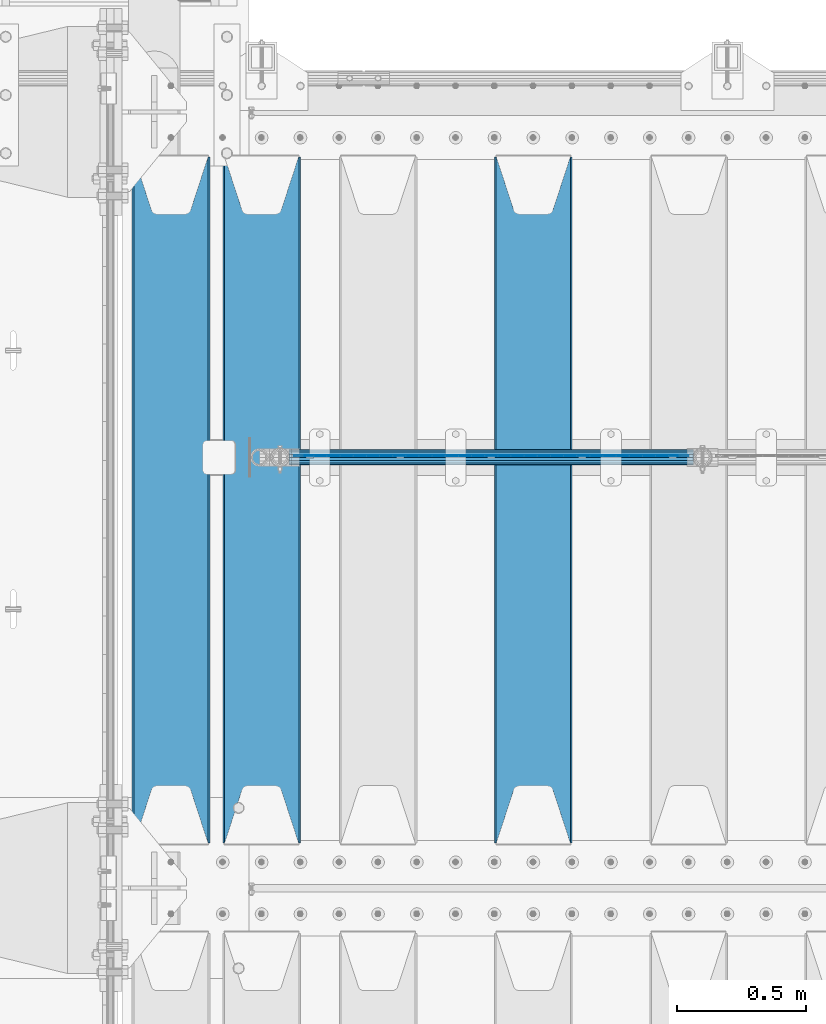
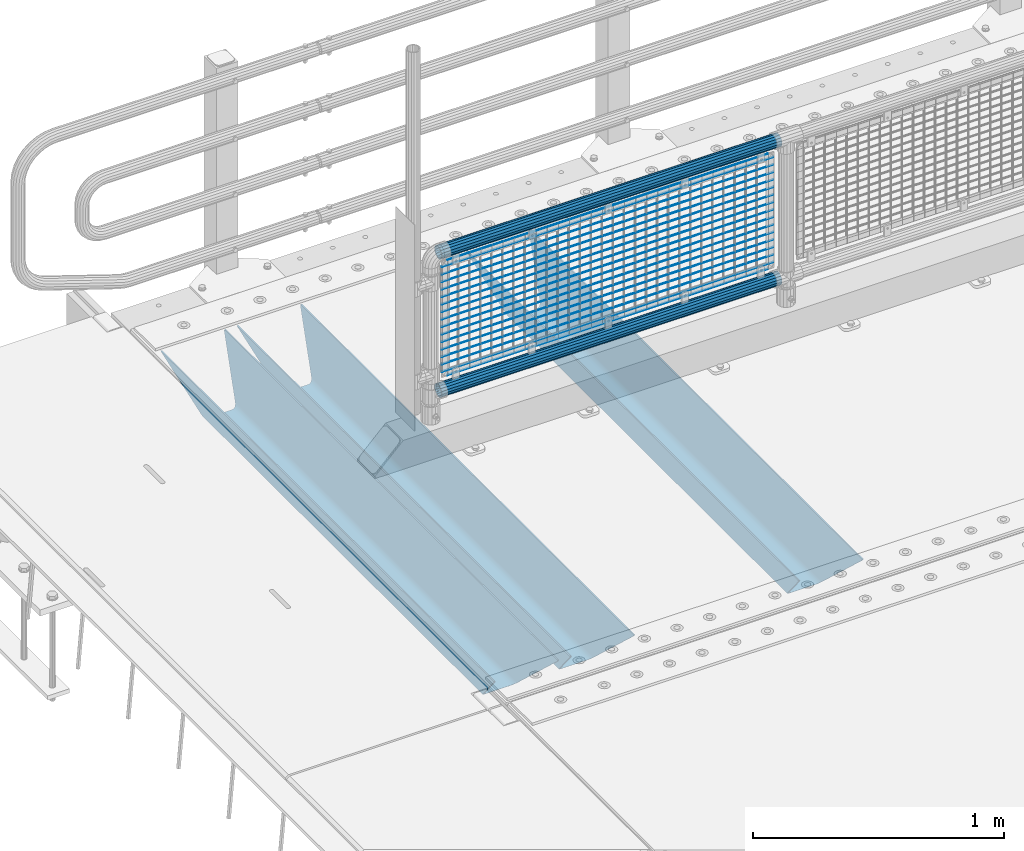
# One storey, part 113 of 242: 22 beams.
"""IFC2X3 building model written with IfcOpenShell, lengths in millimetres."""

from ifc_helpers import new_model, si_unit, frame, origin_with_axes, place, context, subcontext, project, spatial, faceted_brep, material, type_object, element, save


model = new_model("IFC2X3")

# Units and contexts
model_context = context("Model", 3, precision=1e-05, world=origin_with_axes())
body_context = subcontext(model_context, "Body", "Model", "MODEL_VIEW")
ifc_project = project(units=[si_unit("LENGTHUNIT", "METRE", prefix="MILLI"), si_unit("AREAUNIT", "SQUARE_METRE"), si_unit("VOLUMEUNIT", "CUBIC_METRE"), si_unit("MASSUNIT", "GRAM", prefix="KILO"), si_unit("TIMEUNIT", "SECOND"), si_unit("PLANEANGLEUNIT", "RADIAN"), si_unit("SOLIDANGLEUNIT", "STERADIAN"), si_unit("THERMODYNAMICTEMPERATUREUNIT", "DEGREE_CELSIUS"), si_unit("LUMINOUSINTENSITYUNIT", "LUMEN")], contexts=[model_context])

# Site, building, storey
site_placement = place(None, origin_with_axes())
site = spatial("IfcSite", under=ifc_project, at=site_placement, CompositionType="ELEMENT")
building_placement = place(site_placement, origin_with_axes())
building = spatial("IfcBuilding", under=site, at=building_placement, Name="Standard", CompositionType="ELEMENT")
storey_placement = place(building_placement, origin_with_axes())
storey = spatial("IfcBuildingStorey", under=building, at=storey_placement, Name="Undefined", CompositionType="ELEMENT", Elevation=0.0)

# Beams
ifc_material_1 = material(Name="Misc_Undefined")
beam_type_1 = type_object("IfcBeamType", Name="D3", PredefinedType="NOTDEFINED")
for number, where, z_axis, x_axis in (
    (1, (-41774.0, -19329.5, 851.596999999999), (0.0, 0.0, 1.0), (1.0, 0.0, 0.0)),
    (2, (-41774.0, -19329.5, 669.452), (0.0, 0.0, 1.0), (1.0, 0.0, 0.0)),
    (3, (-41774.0, -19329.5, 523.736), (0.0, 0.0, 1.0), (1.0, 0.0, 0.0)),
    (4, (-41774.0, -19329.5, 487.307), (0.0, 0.0, 1.0), (1.0, 0.0, 0.0)),
    (5, (-41774.0, -19329.5, 705.881), (0.0, 0.0, 1.0), (1.0, 0.0, 0.0)),
    (6, (-41774.0, -19329.5, 596.594), (0.0, 0.0, 1.0), (1.0, 0.0, 0.0)),
    (7, (-41774.0, -19329.5, 450.878), (0.0, 0.0, 1.0), (1.0, 0.0, 0.0)),
    (8, (-41774.0, -19329.5, 815.167999999999), (0.0, 0.0, 1.0), (1.0, 0.0, 0.0)),
    (9, (-41774.0, -19329.5, 888.025999999999), (0.0, 0.0, 1.0), (1.0, 0.0, 0.0)),
    (10, (-41774.0, -19329.5, 778.738999999999), (0.0, 0.0, 1.0), (1.0, 0.0, 0.0)),
    (11, (-41774.0, -19329.5, 742.309999999999), (0.0, 0.0, 1.0), (1.0, 0.0, 0.0)),
    (12, (-41774.0, -19329.5, 633.023), (0.0, 0.0, 1.0), (1.0, 0.0, 0.0)),
    (13, (-41774.0, -19329.5, 560.165), (0.0, 0.0, 1.0), (1.0, 0.0, 0.0)),
    (14, (-41774.0, -19329.5, 414.449), (0.0, 0.0, 1.0), (1.0, 0.0, 0.0)),
):
    element("IfcBeam", number, at=place(storey_placement, frame(where, z_axis=z_axis, x_axis=x_axis)), inside=storey, type_object=beam_type_1, material=ifc_material_1, ObjectType="D3", context=body_context, shape_type="Brep", body=[
        faceted_brep([(0.0, -1.50000000000364, 0.0), (-3.63797880709171e-12, -0.750000000003638, -1.29903810567669), (1523.0, -0.75, -1.29903810567669), (1523.0, -1.5, 0.0), (0.0, 0.749999999996362, -1.29903810567669), (1523.0, 0.75, -1.29903810567669), (-3.63797880709171e-12, 1.49999999999636, 0.0), (1523.0, 1.5, 0.0), (0.0, 0.749999999996362, 1.29903810567669), (1523.0, 0.75, 1.29903810567669), (-3.63797880709171e-12, -0.750000000003638, 1.29903810567669), (1523.0, -0.75, 1.29903810567669)], [[[0, 1, 2, 3]], [[1, 4, 5, 2]], [[4, 6, 7, 5]], [[6, 8, 9, 7]], [[8, 10, 11, 9]], [[10, 0, 3, 11]], [[5, 7, 9, 11, 3, 2]], [[10, 8, 6, 4, 1, 0]]]),
    ])
beam_1_placement = place(storey_placement, frame((-41749.0, -19329.5, 353.02), z_axis=(0.0, 0.0, 1.0), x_axis=(1.0, 0.0, 0.0)))
element("IfcBeam", 15, at=beam_1_placement, inside=storey, type_object=beam_type_1, material=ifc_material_1, ObjectType="D3", context=body_context, shape_type="Brep", body=[
    faceted_brep([(0.0, -1.50000000000364, 0.0), (-3.63797880709171e-12, -0.750000000003638, -1.29903810567669), (1473.0, -0.75, -1.29903810567669), (1473.0, -1.5, 0.0), (0.0, 0.749999999996362, -1.29903810567669), (1473.0, 0.75, -1.29903810567663), (-3.63797880709171e-12, 1.49999999999636, 0.0), (1473.0, 1.5, 0.0), (0.0, 0.749999999996362, 1.29903810567669), (1473.0, 0.75, 1.29903810567669), (-3.63797880709171e-12, -0.750000000003638, 1.29903810567669), (1473.0, -0.75, 1.29903810567669)], [[[0, 1, 2, 3]], [[1, 4, 5, 2]], [[4, 6, 7, 5]], [[6, 8, 9, 7]], [[8, 10, 11, 9]], [[10, 0, 3, 11]], [[5, 7, 9, 11, 3, 2]], [[10, 8, 6, 4, 1, 0]]]),
])
beam_2_placement = place(storey_placement, frame((-41774.0, -19329.5, 378.02), z_axis=(0.0, 0.0, 1.0), x_axis=(1.0, 0.0, 0.0)))
element("IfcBeam", 16, at=beam_2_placement, inside=storey, type_object=beam_type_1, material=ifc_material_1, ObjectType="D3", context=body_context, shape_type="Brep", body=[
    faceted_brep([(0.0, -1.50000000000364, 0.0), (-3.63797880709171e-12, -0.750000000003638, -1.29903810567669), (1523.0, -0.75, -1.29903810567669), (1523.0, -1.5, 0.0), (0.0, 0.749999999996362, -1.29903810567669), (1523.0, 0.75, -1.29903810567669), (-3.63797880709171e-12, 1.49999999999636, 0.0), (1523.0, 1.5, 0.0), (0.0, 0.749999999996362, 1.29903810567669), (1523.0, 0.75, 1.29903810567669), (-3.63797880709171e-12, -0.750000000003638, 1.29903810567669), (1523.0, -0.75, 1.29903810567669)], [[[0, 1, 2, 3]], [[1, 4, 5, 2]], [[4, 6, 7, 5]], [[6, 8, 9, 7]], [[8, 10, 11, 9]], [[10, 0, 3, 11]], [[5, 7, 9, 11, 3, 2]], [[10, 8, 6, 4, 1, 0]]]),
])
beam_3_placement = place(storey_placement, frame((-41749.0, -19329.5, 913.02), z_axis=(0.0, 0.0, 1.0), x_axis=(1.0, 0.0, 0.0)))
element("IfcBeam", 17, at=beam_3_placement, inside=storey, type_object=beam_type_1, material=ifc_material_1, ObjectType="D3", context=body_context, shape_type="Brep", body=[
    faceted_brep([(0.0, -1.50000000000364, 0.0), (-3.63797880709171e-12, -0.750000000003638, -1.29903810567669), (1473.0, -0.75, -1.29903810567669), (1473.0, -1.5, 0.0), (0.0, 0.749999999996362, -1.29903810567669), (1473.0, 0.75, -1.29903810567663), (-3.63797880709171e-12, 1.49999999999636, 0.0), (1473.0, 1.5, 0.0), (0.0, 0.749999999996362, 1.29903810567669), (1473.0, 0.75, 1.29903810567669), (-3.63797880709171e-12, -0.750000000003638, 1.29903810567669), (1473.0, -0.75, 1.29903810567669)], [[[0, 1, 2, 3]], [[1, 4, 5, 2]], [[4, 6, 7, 5]], [[6, 8, 9, 7]], [[8, 10, 11, 9]], [[10, 0, 3, 11]], [[5, 7, 9, 11, 3, 2]], [[10, 8, 6, 4, 1, 0]]]),
])
ifc_material_2 = material()
beam_type_2 = type_object("IfcBeamType", PredefinedType="NOTDEFINED")
beam_4_placement = place(storey_placement, frame((-41794.15, -19335.5, 969.849999999999), z_axis=(0.0, 0.0, 1.0), x_axis=(1.0, 0.0, 0.0)))
element("IfcBeam", 18, at=beam_4_placement, inside=storey, type_object=beam_type_2, material=ifc_material_2, context=body_context, shape_type="Brep", body=[
    faceted_brep([(0.0, -25.3499999999985, 0.0), (0.0, -23.4203461491597, 9.70102501045403), (1563.0, -23.4203461491597, 9.70102501045506), (1563.0, -25.3499999999985, 0.0), (0.0, -17.9251569030785, 17.9251569030785), (1563.0, -17.9251569030785, 17.925156903079), (0.0, -9.70102501045403, 23.4203461491597), (1563.0, -9.70102501045403, 23.4203461491611), (0.0, 0.0, 25.3499999999985), (1563.0, 0.0, 25.35), (0.0, 9.70102501045403, 23.4203461491597), (1563.0, 9.70102501045403, 23.4203461491611), (0.0, 17.9251569030785, 17.9251569030785), (1563.0, 17.9251569030785, 17.925156903079), (0.0, 23.4203461491597, 9.70102501045403), (1563.0, 23.4203461491597, 9.70102501045506), (0.0, 25.3499999999985, 0.0), (1563.0, 25.3499999999985, 0.0), (0.0, 23.4203461491597, -9.70102501045403), (1563.0, 23.4203461491597, -9.70102501045506), (0.0, 17.9251569030785, -17.9251569030785), (1563.0, 17.9251569030785, -17.925156903079), (0.0, 9.70102501045403, -23.4203461491597), (1563.0, 9.70102501045403, -23.4203461491611), (0.0, 0.0, -25.3499999999985), (1563.0, 0.0, -25.35), (0.0, -9.70102501045403, -23.4203461491597), (1563.0, -9.70102501045403, -23.4203461491611), (0.0, -17.9251569030785, -17.9251569030785), (1563.0, -17.9251569030785, -17.925156903079), (0.0, -23.4203461491597, -9.70102501045403), (1563.0, -23.4203461491597, -9.70102501045506), (0.0, -30.1500000000015, 0.0), (0.0, -27.8549679052157, -11.5379054858058), (1563.0, -27.8549679052157, -11.5379054858075), (1563.0, -30.1500000000015, 0.0), (0.0, -21.3192694527752, -21.3192694527752), (1563.0, -21.3192694527752, -21.3192694527744), (0.0, -11.5379054858058, -27.8549679052157), (1563.0, -11.5379054858058, -27.8549679052153), (0.0, 0.0, -30.1500000000015), (1563.0, 0.0, -30.15), (0.0, 11.5379054858058, -27.8549679052157), (1563.0, 11.5379054858058, -27.8549679052153), (0.0, 21.3192694527752, -21.3192694527752), (1563.0, 21.3192694527752, -21.3192694527744), (0.0, 27.8549679052157, -11.5379054858058), (1563.0, 27.8549679052157, -11.5379054858074), (0.0, 30.1500000000015, 0.0), (1563.0, 30.1500000000015, 0.0), (0.0, 27.8549679052157, 11.5379054858058), (1563.0, 27.8549679052157, 11.5379054858074), (0.0, 21.3192694527752, 21.3192694527752), (1563.0, 21.3192694527752, 21.3192694527744), (0.0, 11.5379054858058, 27.8549679052157), (1563.0, 11.5379054858058, 27.8549679052153), (0.0, 0.0, 30.1500000000015), (1563.0, 0.0, 30.15), (0.0, -11.5379054858058, 27.8549679052157), (1563.0, -11.5379054858058, 27.8549679052153), (0.0, -21.3192694527752, 21.3192694527752), (1563.0, -21.3192694527752, 21.3192694527744), (0.0, -27.8549679052157, 11.5379054858058), (1563.0, -27.8549679052157, 11.5379054858074)], [[[0, 1, 2, 3]], [[1, 4, 5, 2]], [[4, 6, 7, 5]], [[6, 8, 9, 7]], [[8, 10, 11, 9]], [[10, 12, 13, 11]], [[12, 14, 15, 13]], [[14, 16, 17, 15]], [[16, 18, 19, 17]], [[18, 20, 21, 19]], [[20, 22, 23, 21]], [[22, 24, 25, 23]], [[24, 26, 27, 25]], [[26, 28, 29, 27]], [[28, 30, 31, 29]], [[30, 0, 3, 31]], [[32, 33, 34, 35]], [[33, 36, 37, 34]], [[36, 38, 39, 37]], [[38, 40, 41, 39]], [[40, 42, 43, 41]], [[42, 44, 45, 43]], [[44, 46, 47, 45]], [[46, 48, 49, 47]], [[48, 50, 51, 49]], [[50, 52, 53, 51]], [[52, 54, 55, 53]], [[54, 56, 57, 55]], [[56, 58, 59, 57]], [[58, 60, 61, 59]], [[60, 62, 63, 61]], [[62, 32, 35, 63]], [[37, 39, 41, 43, 45, 47, 49, 51, 53, 55, 57, 59, 61, 63, 35, 34], [5, 7, 9, 11, 13, 15, 17, 19, 21, 23, 25, 27, 29, 31, 3, 2]], [[62, 60, 58, 56, 54, 52, 50, 48, 46, 44, 42, 40, 38, 36, 33, 32], [30, 28, 26, 24, 22, 20, 18, 16, 14, 12, 10, 8, 6, 4, 1, 0]]]),
])
beam_5_placement = place(storey_placement, frame((-41794.15, -19335.5, 298.170000000001), z_axis=(0.0, 0.0, 1.0), x_axis=(1.0, 0.0, 0.0)))
element("IfcBeam", 19, at=beam_5_placement, inside=storey, type_object=beam_type_2, material=ifc_material_2, context=body_context, shape_type="Brep", body=[
    faceted_brep([(0.0, -25.3499999999985, 0.0), (0.0, -23.4203461491597, 9.70102501045403), (1563.0, -23.4203461491597, 9.70102501045506), (1563.0, -25.3499999999985, 0.0), (0.0, -17.9251569030785, 17.9251569030785), (1563.0, -17.9251569030785, 17.925156903079), (0.0, -9.70102501045403, 23.4203461491597), (1563.0, -9.70102501045403, 23.4203461491611), (0.0, 0.0, 25.3499999999985), (1563.0, 0.0, 25.35), (0.0, 9.70102501045403, 23.4203461491597), (1563.0, 9.70102501045403, 23.4203461491611), (0.0, 17.9251569030785, 17.9251569030785), (1563.0, 17.9251569030785, 17.925156903079), (0.0, 23.4203461491597, 9.70102501045403), (1563.0, 23.4203461491597, 9.70102501045506), (0.0, 25.3499999999985, 0.0), (1563.0, 25.3499999999985, 0.0), (0.0, 23.4203461491597, -9.70102501045403), (1563.0, 23.4203461491597, -9.70102501045506), (0.0, 17.9251569030785, -17.9251569030785), (1563.0, 17.9251569030785, -17.925156903079), (0.0, 9.70102501045403, -23.4203461491597), (1563.0, 9.70102501045403, -23.4203461491611), (0.0, 0.0, -25.3499999999985), (1563.0, 0.0, -25.35), (0.0, -9.70102501045403, -23.4203461491597), (1563.0, -9.70102501045403, -23.4203461491611), (0.0, -17.9251569030785, -17.9251569030785), (1563.0, -17.9251569030785, -17.925156903079), (0.0, -23.4203461491597, -9.70102501045403), (1563.0, -23.4203461491597, -9.70102501045506), (0.0, -30.1500000000015, 0.0), (0.0, -27.8549679052157, -11.5379054858058), (1563.0, -27.8549679052157, -11.5379054858075), (1563.0, -30.1500000000015, 0.0), (0.0, -21.3192694527752, -21.3192694527752), (1563.0, -21.3192694527752, -21.3192694527744), (0.0, -11.5379054858058, -27.8549679052157), (1563.0, -11.5379054858058, -27.8549679052153), (0.0, 0.0, -30.1500000000015), (1563.0, 0.0, -30.15), (0.0, 11.5379054858058, -27.8549679052157), (1563.0, 11.5379054858058, -27.8549679052153), (0.0, 21.3192694527752, -21.3192694527752), (1563.0, 21.3192694527752, -21.3192694527744), (0.0, 27.8549679052157, -11.5379054858058), (1563.0, 27.8549679052157, -11.5379054858074), (0.0, 30.1500000000015, 0.0), (1563.0, 30.1500000000015, 0.0), (0.0, 27.8549679052157, 11.5379054858058), (1563.0, 27.8549679052157, 11.5379054858074), (0.0, 21.3192694527752, 21.3192694527752), (1563.0, 21.3192694527752, 21.3192694527744), (0.0, 11.5379054858058, 27.8549679052157), (1563.0, 11.5379054858058, 27.8549679052153), (0.0, 0.0, 30.1500000000015), (1563.0, 0.0, 30.15), (0.0, -11.5379054858058, 27.8549679052157), (1563.0, -11.5379054858058, 27.8549679052153), (0.0, -21.3192694527752, 21.3192694527752), (1563.0, -21.3192694527752, 21.3192694527744), (0.0, -27.8549679052157, 11.5379054858058), (1563.0, -27.8549679052157, 11.5379054858074)], [[[0, 1, 2, 3]], [[1, 4, 5, 2]], [[4, 6, 7, 5]], [[6, 8, 9, 7]], [[8, 10, 11, 9]], [[10, 12, 13, 11]], [[12, 14, 15, 13]], [[14, 16, 17, 15]], [[16, 18, 19, 17]], [[18, 20, 21, 19]], [[20, 22, 23, 21]], [[22, 24, 25, 23]], [[24, 26, 27, 25]], [[26, 28, 29, 27]], [[28, 30, 31, 29]], [[30, 0, 3, 31]], [[32, 33, 34, 35]], [[33, 36, 37, 34]], [[36, 38, 39, 37]], [[38, 40, 41, 39]], [[40, 42, 43, 41]], [[42, 44, 45, 43]], [[44, 46, 47, 45]], [[46, 48, 49, 47]], [[48, 50, 51, 49]], [[50, 52, 53, 51]], [[52, 54, 55, 53]], [[54, 56, 57, 55]], [[56, 58, 59, 57]], [[58, 60, 61, 59]], [[60, 62, 63, 61]], [[62, 32, 35, 63]], [[37, 39, 41, 43, 45, 47, 49, 51, 53, 55, 57, 59, 61, 63, 35, 34], [5, 7, 9, 11, 13, 15, 17, 19, 21, 23, 25, 27, 29, 31, 3, 2]], [[62, 60, 58, 56, 54, 52, 50, 48, 46, 44, 42, 40, 38, 36, 33, 32], [30, 28, 26, 24, 22, 20, 18, 16, 14, 12, 10, 8, 6, 4, 1, 0]]]),
])
ifc_material_3 = material(Name="STEEL/S355N")
beam_type_3 = type_object("IfcBeamType", PredefinedType="NOTDEFINED")
beam_6_placement = place(storey_placement, frame((-40850.0, -20825.0, -115.0), z_axis=(0.0, 0.0, 1.0), x_axis=(0.0, 1.0, 0.0)))
element("IfcBeam", 20, at=beam_6_placement, inside=storey, type_object=beam_type_3, material=ifc_material_3, context=body_context, shape_type="Brep", body=[
    faceted_brep([(0.0, 150.0, 115.0), (0.0, 143.689999999999, 115.0), (2650.00000000297, 143.689999999999, 115.0), (2650.00000000297, 150.0, 115.0), (2650.00000000297, 142.059565218402, 110.000000003099), (2650.00000000297, 148.369565218403, 110.000000003099), (2441.90079219209, -80.1103600731112, -98.0992078077845), (2437.7588105432, -77.5672621345584, -102.241189456673), (2434.06523489747, -74.4080125315522, -105.934765102404), (2430.91086095089, -70.710272125576, -109.089139048974), (2428.37322971128, -66.5649389910068, -111.626770288588), (2426.51472138055, -62.0739139532889, -113.485278619323), (2425.38102192092, -57.3475956567672, -114.618978078955), (2424.99999999987, -52.5021667386536, -115.0), (2424.99999999987, 52.5021667386536, -115.0), (2425.38102192092, 57.3475956567672, -114.618978078955), (2426.51472138055, 62.0739139532889, -113.485278619323), (2428.37322971128, 66.5649389910068, -111.626770288588), (2430.91086095089, 70.710272125576, -109.089139048974), (2434.06523489747, 74.4080125315522, -105.934765102404), (2437.7588105432, 77.5672621345584, -102.241189456673), (2441.90079219209, 80.1103600731112, -98.0992078077846), (2446.38936140511, 81.9747917625791, -93.6106385947584), (2448.2494850041, 76.2713538057251, -91.7505149957729), (2444.62967112262, 74.76777986261, -95.3703288772456), (2441.28936334126, 72.7168944282894, -98.710636658607), (2438.31067330438, 70.1691124903846, -101.689326695487), (2435.76682334747, 67.1870637758839, -104.233176652398), (2433.72034654133, 63.8440531834895, -106.279653458539), (2432.22154950042, 60.222258798236, -107.778450499454), (2431.30727574265, 56.4107117849089, -108.692724257221), (2430.99999999987, 52.5031078186876, -109.0), (2430.99999999987, -52.5031078186876, -109.0), (2431.30727574265, -56.4107117849089, -108.692724257221), (2432.22154950042, -60.222258798236, -107.778450499454), (2433.72034654133, -63.8440531834895, -106.279653458539), (2435.76682334747, -67.1870637758839, -104.233176652398), (2438.31067330438, -70.1691124903846, -101.689326695487), (2441.28936334126, -72.7168944282894, -98.7106366586071), (2444.62967112262, -74.76777986261, -95.3703288772457), (2448.2494850041, -76.2713538057251, -91.7505149957729), (2650.00000000297, -142.059565218402, 110.000000003099), (2650.00000000297, -148.369565218403, 110.000000003099), (2446.38936140511, -81.9747917625791, -93.6106385947584), (2650.00000000297, -143.689999999999, 115.0), (2650.00000000297, -150.0, 115.0), (0.0, -143.689999999999, 115.0), (0.0, -150.0, 115.0), (0.0, -148.369565218261, 110.000000002669), (203.610638597427, -81.9747917625791, -93.6106385947584), (208.099207810454, -80.1103600731112, -98.0992078077845), (212.241189459342, -77.5672621345584, -102.241189456673), (215.934765105074, -74.4080125315522, -105.934765102404), (219.089139051644, -70.710272125576, -109.089139048974), (221.626770291256, -66.5649389910068, -111.626770288588), (223.485278621993, -62.0739139532889, -113.485278619323), (224.618978081624, -57.3475956567672, -114.618978078955), (225.00000000267, -52.5021667386536, -115.0), (225.00000000267, 52.5021667386536, -115.0), (224.618978081624, 57.3475956567672, -114.618978078955), (223.485278621993, 62.0739139532889, -113.485278619323), (221.626770291256, 66.5649389910068, -111.626770288588), (219.089139051644, 70.710272125576, -109.089139048974), (215.934765105074, 74.4080125315522, -105.934765102404), (212.241189459342, 77.5672621345584, -102.241189456673), (208.099207810454, 80.1103600731112, -98.0992078077846), (203.610638597427, 81.9747917625791, -93.6106385947584), (0.0, 148.369565218261, 110.000000002669), (0.0, 142.05956521826, 110.000000002669), (201.750514998443, 76.2713538057251, -91.7505149957729), (205.370328879915, 74.76777986261, -95.3703288772456), (208.710636661275, 72.7168944282894, -98.710636658607), (211.689326698157, 70.1691124903846, -101.689326695487), (214.233176655067, 67.1870637758839, -104.233176652398), (216.279653461206, 63.8440531834895, -106.279653458539), (217.778450502123, 60.222258798236, -107.778450499454), (218.69272425989, 56.4107117849089, -108.692724257221), (219.00000000267, 52.5031078186876, -109.0), (219.00000000267, -52.5031078186876, -109.0), (218.69272425989, -56.4107117849089, -108.692724257221), (217.778450502123, -60.222258798236, -107.778450499454), (216.279653461206, -63.8440531834895, -106.279653458539), (214.233176655067, -67.1870637758839, -104.233176652398), (211.689326698157, -70.1691124903846, -101.689326695487), (208.710636661275, -72.7168944282894, -98.7106366586071), (205.370328879915, -74.76777986261, -95.3703288772457), (201.750514998443, -76.2713538057251, -91.7505149957729), (0.0, -142.05956521826, 110.000000002669)], [[[0, 1, 2, 3]], [[3, 2, 4, 5]], [[6, 7, 8, 9, 10, 11, 12, 13, 14, 15, 16, 17, 18, 19, 20, 21, 22, 5, 4, 23, 24, 25, 26, 27, 28, 29, 30, 31, 32, 33, 34, 35, 36, 37, 38, 39, 40, 41, 42, 43]], [[44, 45, 42, 41]], [[46, 47, 45, 44]], [[43, 42, 45, 47, 48, 49]], [[6, 43, 49, 50]], [[7, 6, 50, 51]], [[8, 7, 51, 52]], [[9, 8, 52, 53]], [[10, 9, 53, 54]], [[11, 10, 54, 55]], [[12, 11, 55, 56]], [[13, 12, 56, 57]], [[14, 13, 57, 58]], [[15, 14, 58, 59]], [[16, 15, 59, 60]], [[17, 16, 60, 61]], [[18, 17, 61, 62]], [[19, 18, 62, 63]], [[20, 19, 63, 64]], [[21, 20, 64, 65]], [[22, 21, 65, 66]], [[0, 3, 5, 22, 66, 67]], [[1, 0, 67, 68]], [[23, 4, 2, 1, 68, 69]], [[24, 23, 69, 70]], [[25, 24, 70, 71]], [[26, 25, 71, 72]], [[27, 26, 72, 73]], [[28, 27, 73, 74]], [[29, 28, 74, 75]], [[30, 29, 75, 76]], [[31, 30, 76, 77]], [[32, 31, 77, 78]], [[33, 32, 78, 79]], [[34, 33, 79, 80]], [[35, 34, 80, 81]], [[36, 35, 81, 82]], [[37, 36, 82, 83]], [[38, 37, 83, 84]], [[39, 38, 84, 85]], [[40, 39, 85, 86]], [[46, 44, 41, 40, 86, 87]], [[47, 46, 87, 48]], [[86, 85, 84, 83, 82, 81, 80, 79, 78, 77, 76, 75, 74, 73, 72, 71, 70, 69, 68, 67, 66, 65, 64, 63, 62, 61, 60, 59, 58, 57, 56, 55, 54, 53, 52, 51, 50, 49, 48, 87]]]),
])
beam_7_placement = place(storey_placement, frame((-41900.0, -20825.0, -115.0), z_axis=(0.0, 0.0, 1.0), x_axis=(0.0, 1.0, 0.0)))
element("IfcBeam", 21, at=beam_7_placement, inside=storey, type_object=beam_type_3, material=ifc_material_3, context=body_context, shape_type="Brep", body=[
    faceted_brep([(0.0, 150.0, 115.0), (0.0, 143.689999999999, 115.0), (2650.00000000297, 143.689999999999, 115.0), (2650.00000000297, 150.0, 115.0), (2650.00000000297, 142.059565218402, 110.000000003099), (2650.00000000297, 148.369565218403, 110.000000003099), (2441.90079219209, -80.1103600731112, -98.0992078077845), (2437.7588105432, -77.5672621345584, -102.241189456673), (2434.06523489747, -74.4080125315522, -105.934765102404), (2430.91086095089, -70.710272125576, -109.089139048974), (2428.37322971128, -66.5649389910068, -111.626770288588), (2426.51472138055, -62.0739139532889, -113.485278619323), (2425.38102192092, -57.3475956567672, -114.618978078955), (2424.99999999987, -52.5021667386536, -115.0), (2424.99999999987, 52.5021667386536, -115.0), (2425.38102192092, 57.3475956567672, -114.618978078955), (2426.51472138055, 62.0739139532889, -113.485278619323), (2428.37322971128, 66.5649389910068, -111.626770288588), (2430.91086095089, 70.710272125576, -109.089139048974), (2434.06523489747, 74.4080125315522, -105.934765102404), (2437.7588105432, 77.5672621345584, -102.241189456673), (2441.90079219209, 80.1103600731112, -98.0992078077846), (2446.38936140511, 81.9747917625791, -93.6106385947584), (2448.2494850041, 76.2713538057251, -91.7505149957729), (2444.62967112262, 74.76777986261, -95.3703288772456), (2441.28936334126, 72.7168944282894, -98.710636658607), (2438.31067330438, 70.1691124903846, -101.689326695487), (2435.76682334747, 67.1870637758839, -104.233176652398), (2433.72034654133, 63.8440531834895, -106.279653458539), (2432.22154950042, 60.222258798236, -107.778450499454), (2431.30727574265, 56.4107117849089, -108.692724257221), (2430.99999999987, 52.5031078186876, -109.0), (2430.99999999987, -52.5031078186876, -109.0), (2431.30727574265, -56.4107117849089, -108.692724257221), (2432.22154950042, -60.222258798236, -107.778450499454), (2433.72034654133, -63.8440531834895, -106.279653458539), (2435.76682334747, -67.1870637758839, -104.233176652398), (2438.31067330438, -70.1691124903846, -101.689326695487), (2441.28936334126, -72.7168944282894, -98.7106366586071), (2444.62967112262, -74.76777986261, -95.3703288772457), (2448.2494850041, -76.2713538057251, -91.7505149957729), (2650.00000000297, -142.059565218402, 110.000000003099), (2650.00000000297, -148.369565218403, 110.000000003099), (2446.38936140511, -81.9747917625791, -93.6106385947584), (2650.00000000297, -143.689999999999, 115.0), (2650.00000000297, -150.0, 115.0), (0.0, -143.689999999999, 115.0), (0.0, -150.0, 115.0), (0.0, -148.369565218261, 110.000000002669), (203.610638597427, -81.9747917625791, -93.6106385947584), (208.099207810454, -80.1103600731112, -98.0992078077845), (212.241189459342, -77.5672621345584, -102.241189456673), (215.934765105074, -74.4080125315522, -105.934765102404), (219.089139051644, -70.710272125576, -109.089139048974), (221.626770291256, -66.5649389910068, -111.626770288588), (223.485278621993, -62.0739139532889, -113.485278619323), (224.618978081624, -57.3475956567672, -114.618978078955), (225.00000000267, -52.5021667386536, -115.0), (225.00000000267, 52.5021667386536, -115.0), (224.618978081624, 57.3475956567672, -114.618978078955), (223.485278621993, 62.0739139532889, -113.485278619323), (221.626770291256, 66.5649389910068, -111.626770288588), (219.089139051644, 70.710272125576, -109.089139048974), (215.934765105074, 74.4080125315522, -105.934765102404), (212.241189459342, 77.5672621345584, -102.241189456673), (208.099207810454, 80.1103600731112, -98.0992078077846), (203.610638597427, 81.9747917625791, -93.6106385947584), (0.0, 148.369565218261, 110.000000002669), (0.0, 142.05956521826, 110.000000002669), (201.750514998443, 76.2713538057251, -91.7505149957729), (205.370328879915, 74.76777986261, -95.3703288772456), (208.710636661275, 72.7168944282894, -98.710636658607), (211.689326698157, 70.1691124903846, -101.689326695487), (214.233176655067, 67.1870637758839, -104.233176652398), (216.279653461206, 63.8440531834895, -106.279653458539), (217.778450502123, 60.222258798236, -107.778450499454), (218.69272425989, 56.4107117849089, -108.692724257221), (219.00000000267, 52.5031078186876, -109.0), (219.00000000267, -52.5031078186876, -109.0), (218.69272425989, -56.4107117849089, -108.692724257221), (217.778450502123, -60.222258798236, -107.778450499454), (216.279653461206, -63.8440531834895, -106.279653458539), (214.233176655067, -67.1870637758839, -104.233176652398), (211.689326698157, -70.1691124903846, -101.689326695487), (208.710636661275, -72.7168944282894, -98.7106366586071), (205.370328879915, -74.76777986261, -95.3703288772457), (201.750514998443, -76.2713538057251, -91.7505149957729), (0.0, -142.05956521826, 110.000000002669)], [[[0, 1, 2, 3]], [[3, 2, 4, 5]], [[6, 7, 8, 9, 10, 11, 12, 13, 14, 15, 16, 17, 18, 19, 20, 21, 22, 5, 4, 23, 24, 25, 26, 27, 28, 29, 30, 31, 32, 33, 34, 35, 36, 37, 38, 39, 40, 41, 42, 43]], [[44, 45, 42, 41]], [[46, 47, 45, 44]], [[43, 42, 45, 47, 48, 49]], [[6, 43, 49, 50]], [[7, 6, 50, 51]], [[8, 7, 51, 52]], [[9, 8, 52, 53]], [[10, 9, 53, 54]], [[11, 10, 54, 55]], [[12, 11, 55, 56]], [[13, 12, 56, 57]], [[14, 13, 57, 58]], [[15, 14, 58, 59]], [[16, 15, 59, 60]], [[17, 16, 60, 61]], [[18, 17, 61, 62]], [[19, 18, 62, 63]], [[20, 19, 63, 64]], [[21, 20, 64, 65]], [[22, 21, 65, 66]], [[0, 3, 5, 22, 66, 67]], [[1, 0, 67, 68]], [[23, 4, 2, 1, 68, 69]], [[24, 23, 69, 70]], [[25, 24, 70, 71]], [[26, 25, 71, 72]], [[27, 26, 72, 73]], [[28, 27, 73, 74]], [[29, 28, 74, 75]], [[30, 29, 75, 76]], [[31, 30, 76, 77]], [[32, 31, 77, 78]], [[33, 32, 78, 79]], [[34, 33, 79, 80]], [[35, 34, 80, 81]], [[36, 35, 81, 82]], [[37, 36, 82, 83]], [[38, 37, 83, 84]], [[39, 38, 84, 85]], [[40, 39, 85, 86]], [[46, 44, 41, 40, 86, 87]], [[47, 46, 87, 48]], [[86, 85, 84, 83, 82, 81, 80, 79, 78, 77, 76, 75, 74, 73, 72, 71, 70, 69, 68, 67, 66, 65, 64, 63, 62, 61, 60, 59, 58, 57, 56, 55, 54, 53, 52, 51, 50, 49, 48, 87]]]),
])
beam_8_placement = place(storey_placement, frame((-42250.0, -20825.0, -115.0), z_axis=(0.0, 0.0, 1.0), x_axis=(0.0, 1.0, 0.0)))
element("IfcBeam", 22, at=beam_8_placement, inside=storey, type_object=beam_type_3, material=ifc_material_3, context=body_context, shape_type="Brep", body=[
    faceted_brep([(0.0, 150.0, 115.0), (0.0, 143.689999999999, 115.0), (2650.00000000297, 143.689999999999, 115.0), (2650.00000000297, 150.0, 115.0), (2650.00000000297, 142.059565218402, 110.000000003099), (2650.00000000297, 148.369565218403, 110.000000003099), (2441.90079219209, -80.1103600731112, -98.0992078077845), (2437.7588105432, -77.5672621345584, -102.241189456673), (2434.06523489747, -74.4080125315522, -105.934765102404), (2430.91086095089, -70.710272125576, -109.089139048974), (2428.37322971128, -66.5649389910068, -111.626770288588), (2426.51472138055, -62.0739139532889, -113.485278619323), (2425.38102192092, -57.3475956567672, -114.618978078955), (2424.99999999987, -52.5021667386536, -115.0), (2424.99999999987, 52.5021667386536, -115.0), (2425.38102192092, 57.3475956567672, -114.618978078955), (2426.51472138055, 62.0739139532889, -113.485278619323), (2428.37322971128, 66.5649389910068, -111.626770288588), (2430.91086095089, 70.710272125576, -109.089139048974), (2434.06523489747, 74.4080125315522, -105.934765102404), (2437.7588105432, 77.5672621345584, -102.241189456673), (2441.90079219209, 80.1103600731112, -98.0992078077846), (2446.38936140511, 81.9747917625791, -93.6106385947584), (2448.2494850041, 76.2713538057251, -91.7505149957729), (2444.62967112262, 74.76777986261, -95.3703288772456), (2441.28936334126, 72.7168944282894, -98.710636658607), (2438.31067330438, 70.1691124903846, -101.689326695487), (2435.76682334747, 67.1870637758839, -104.233176652398), (2433.72034654133, 63.8440531834895, -106.279653458539), (2432.22154950042, 60.222258798236, -107.778450499454), (2431.30727574265, 56.4107117849089, -108.692724257221), (2430.99999999987, 52.5031078186876, -109.0), (2430.99999999987, -52.5031078186876, -109.0), (2431.30727574265, -56.4107117849089, -108.692724257221), (2432.22154950042, -60.222258798236, -107.778450499454), (2433.72034654133, -63.8440531834895, -106.279653458539), (2435.76682334747, -67.1870637758839, -104.233176652398), (2438.31067330438, -70.1691124903846, -101.689326695487), (2441.28936334126, -72.7168944282894, -98.7106366586071), (2444.62967112262, -74.76777986261, -95.3703288772457), (2448.2494850041, -76.2713538057251, -91.7505149957729), (2650.00000000297, -142.059565218402, 110.000000003099), (2650.00000000297, -148.369565218403, 110.000000003099), (2446.38936140511, -81.9747917625791, -93.6106385947584), (2650.00000000297, -143.689999999999, 115.0), (2650.00000000297, -150.0, 115.0), (0.0, -143.689999999999, 115.0), (0.0, -150.0, 115.0), (0.0, -148.369565218261, 110.000000002669), (203.610638597427, -81.9747917625791, -93.6106385947584), (208.099207810454, -80.1103600731112, -98.0992078077845), (212.241189459342, -77.5672621345584, -102.241189456673), (215.934765105074, -74.4080125315522, -105.934765102404), (219.089139051644, -70.710272125576, -109.089139048974), (221.626770291256, -66.5649389910068, -111.626770288588), (223.485278621993, -62.0739139532889, -113.485278619323), (224.618978081624, -57.3475956567672, -114.618978078955), (225.00000000267, -52.5021667386536, -115.0), (225.00000000267, 52.5021667386536, -115.0), (224.618978081624, 57.3475956567672, -114.618978078955), (223.485278621993, 62.0739139532889, -113.485278619323), (221.626770291256, 66.5649389910068, -111.626770288588), (219.089139051644, 70.710272125576, -109.089139048974), (215.934765105074, 74.4080125315522, -105.934765102404), (212.241189459342, 77.5672621345584, -102.241189456673), (208.099207810454, 80.1103600731112, -98.0992078077846), (203.610638597427, 81.9747917625791, -93.6106385947584), (0.0, 148.369565218261, 110.000000002669), (0.0, 142.05956521826, 110.000000002669), (201.750514998443, 76.2713538057251, -91.7505149957729), (205.370328879915, 74.76777986261, -95.3703288772456), (208.710636661275, 72.7168944282894, -98.710636658607), (211.689326698157, 70.1691124903846, -101.689326695487), (214.233176655067, 67.1870637758839, -104.233176652398), (216.279653461206, 63.8440531834895, -106.279653458539), (217.778450502123, 60.222258798236, -107.778450499454), (218.69272425989, 56.4107117849089, -108.692724257221), (219.00000000267, 52.5031078186876, -109.0), (219.00000000267, -52.5031078186876, -109.0), (218.69272425989, -56.4107117849089, -108.692724257221), (217.778450502123, -60.222258798236, -107.778450499454), (216.279653461206, -63.8440531834895, -106.279653458539), (214.233176655067, -67.1870637758839, -104.233176652398), (211.689326698157, -70.1691124903846, -101.689326695487), (208.710636661275, -72.7168944282894, -98.7106366586071), (205.370328879915, -74.76777986261, -95.3703288772457), (201.750514998443, -76.2713538057251, -91.7505149957729), (0.0, -142.05956521826, 110.000000002669)], [[[0, 1, 2, 3]], [[3, 2, 4, 5]], [[6, 7, 8, 9, 10, 11, 12, 13, 14, 15, 16, 17, 18, 19, 20, 21, 22, 5, 4, 23, 24, 25, 26, 27, 28, 29, 30, 31, 32, 33, 34, 35, 36, 37, 38, 39, 40, 41, 42, 43]], [[44, 45, 42, 41]], [[46, 47, 45, 44]], [[43, 42, 45, 47, 48, 49]], [[6, 43, 49, 50]], [[7, 6, 50, 51]], [[8, 7, 51, 52]], [[9, 8, 52, 53]], [[10, 9, 53, 54]], [[11, 10, 54, 55]], [[12, 11, 55, 56]], [[13, 12, 56, 57]], [[14, 13, 57, 58]], [[15, 14, 58, 59]], [[16, 15, 59, 60]], [[17, 16, 60, 61]], [[18, 17, 61, 62]], [[19, 18, 62, 63]], [[20, 19, 63, 64]], [[21, 20, 64, 65]], [[22, 21, 65, 66]], [[0, 3, 5, 22, 66, 67]], [[1, 0, 67, 68]], [[23, 4, 2, 1, 68, 69]], [[24, 23, 69, 70]], [[25, 24, 70, 71]], [[26, 25, 71, 72]], [[27, 26, 72, 73]], [[28, 27, 73, 74]], [[29, 28, 74, 75]], [[30, 29, 75, 76]], [[31, 30, 76, 77]], [[32, 31, 77, 78]], [[33, 32, 78, 79]], [[34, 33, 79, 80]], [[35, 34, 80, 81]], [[36, 35, 81, 82]], [[37, 36, 82, 83]], [[38, 37, 83, 84]], [[39, 38, 84, 85]], [[40, 39, 85, 86]], [[46, 44, 41, 40, 86, 87]], [[47, 46, 87, 48]], [[86, 85, 84, 83, 82, 81, 80, 79, 78, 77, 76, 75, 74, 73, 72, 71, 70, 69, 68, 67, 66, 65, 64, 63, 62, 61, 60, 59, 58, 57, 56, 55, 54, 53, 52, 51, 50, 49, 48, 87]]]),
])

save(model, "model.ifc")
